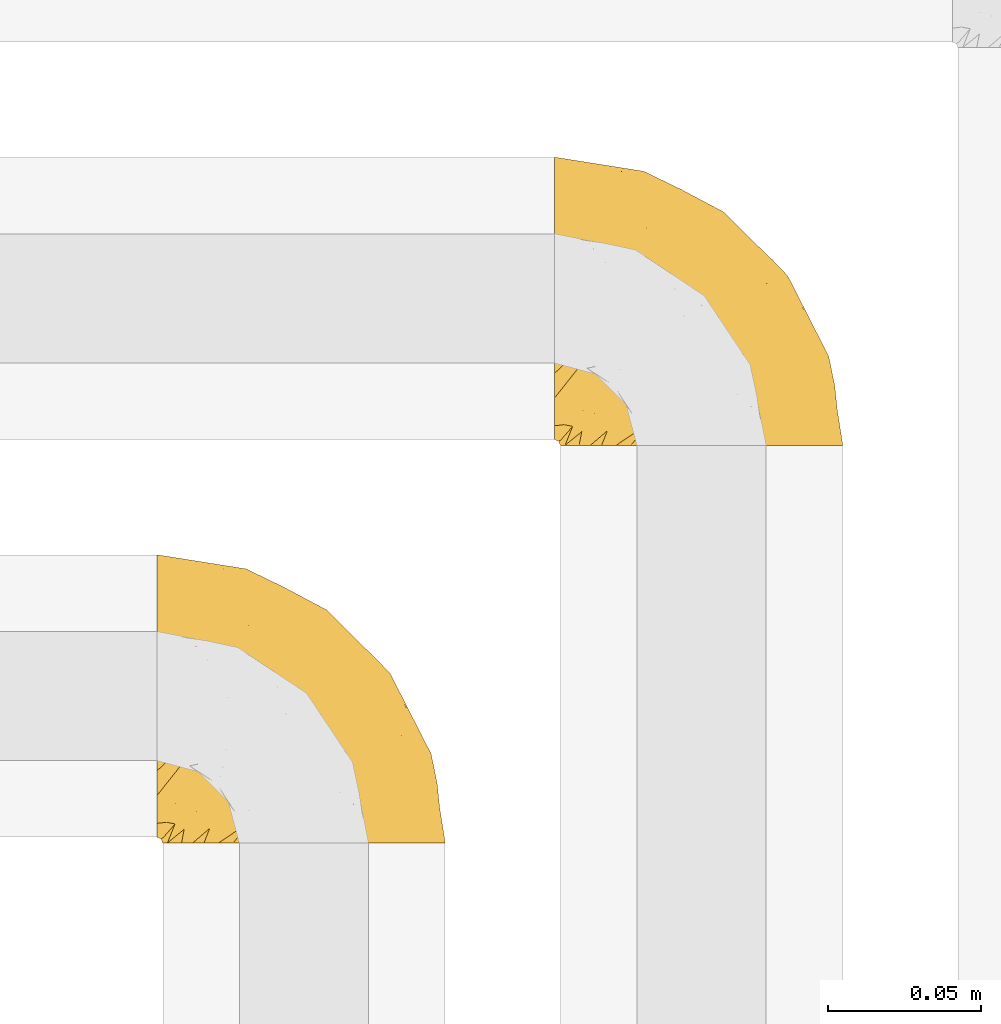
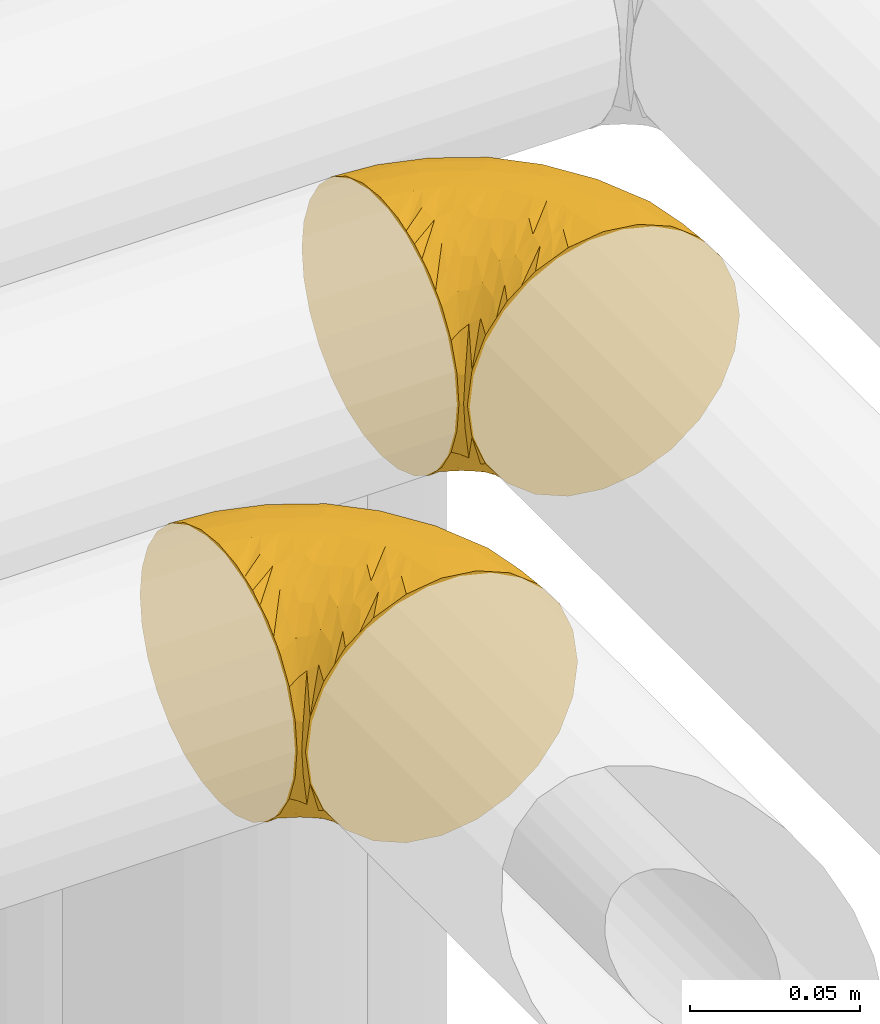
# One storey, part 261 of 827: 2 coverings.
"""IFC2X3 building model written with IfcOpenShell, lengths in millimetres."""

from ifc_helpers import new_model, entity, si_unit, converted_unit, derived_unit, direction, frame, origin, place, context, subcontext, project, spatial, faceted_brep, element, save


model = new_model("IFC2X3")

# Units and contexts
model_context = context("Model", 3, precision=0.01, world=origin(), true_north=direction((6.12303176911189e-17, 1.0)))
body_context = subcontext(model_context, "Body", "Model", "MODEL_VIEW")
ifc_project = project(units=[si_unit("LENGTHUNIT", "METRE", prefix="MILLI"), si_unit("AREAUNIT", "SQUARE_METRE"), si_unit("VOLUMEUNIT", "CUBIC_METRE"), converted_unit("PLANEANGLEUNIT", "DEGREE", entity("IfcRatioMeasure", 0.0174532925199433), si_unit("PLANEANGLEUNIT", "RADIAN"), dimensions=[0, 0, 0, 0, 0, 0, 0]), si_unit("MASSUNIT", "GRAM", prefix="KILO"), derived_unit("MASSDENSITYUNIT", [(si_unit("MASSUNIT", "GRAM", prefix="KILO"), 1), (si_unit("LENGTHUNIT", "METRE"), -3)]), derived_unit("MOMENTOFINERTIAUNIT", [(si_unit("LENGTHUNIT", "METRE"), 4)]), si_unit("TIMEUNIT", "SECOND"), si_unit("FREQUENCYUNIT", "HERTZ"), si_unit("THERMODYNAMICTEMPERATUREUNIT", "DEGREE_CELSIUS"), derived_unit("THERMALTRANSMITTANCEUNIT", [(si_unit("MASSUNIT", "GRAM", prefix="KILO"), 1), (si_unit("THERMODYNAMICTEMPERATUREUNIT", "KELVIN"), -1), (si_unit("TIMEUNIT", "SECOND"), -3)]), derived_unit("VOLUMETRICFLOWRATEUNIT", [(si_unit("LENGTHUNIT", "METRE"), 3), (si_unit("TIMEUNIT", "SECOND"), -1)]), derived_unit("MASSFLOWRATEUNIT", [(si_unit("MASSUNIT", "GRAM", prefix="KILO"), 1), (si_unit("TIMEUNIT", "SECOND"), -1)]), derived_unit("ROTATIONALFREQUENCYUNIT", [(si_unit("TIMEUNIT", "SECOND"), -1)]), si_unit("ELECTRICCURRENTUNIT", "AMPERE"), si_unit("ELECTRICVOLTAGEUNIT", "VOLT"), si_unit("POWERUNIT", "WATT"), si_unit("FORCEUNIT", "NEWTON", prefix="KILO"), si_unit("ILLUMINANCEUNIT", "LUX"), si_unit("LUMINOUSFLUXUNIT", "LUMEN"), si_unit("LUMINOUSINTENSITYUNIT", "CANDELA"), derived_unit("USERDEFINED", [(si_unit("MASSUNIT", "GRAM", prefix="KILO"), -1), (si_unit("LENGTHUNIT", "METRE"), -2), (si_unit("TIMEUNIT", "SECOND"), 3), (si_unit("LUMINOUSFLUXUNIT", "LUMEN"), 1)]), derived_unit("LINEARVELOCITYUNIT", [(si_unit("LENGTHUNIT", "METRE"), 1), (si_unit("TIMEUNIT", "SECOND"), -1)]), si_unit("PRESSUREUNIT", "PASCAL"), derived_unit("USERDEFINED", [(si_unit("LENGTHUNIT", "METRE"), -2), (si_unit("MASSUNIT", "GRAM", prefix="KILO"), 1), (si_unit("TIMEUNIT", "SECOND"), -2)]), derived_unit("LINEARFORCEUNIT", [(si_unit("MASSUNIT", "GRAM", prefix="KILO"), 1), (si_unit("LENGTHUNIT", "METRE"), 1), (si_unit("TIMEUNIT", "SECOND"), -2), (si_unit("LENGTHUNIT", "METRE"), -1)]), derived_unit("PLANARFORCEUNIT", [(si_unit("MASSUNIT", "GRAM", prefix="KILO"), 1), (si_unit("LENGTHUNIT", "METRE"), 1), (si_unit("TIMEUNIT", "SECOND"), -2), (si_unit("LENGTHUNIT", "METRE"), -2)])], contexts=[model_context])

# Site, building, storey
site_placement = place(None, origin())
site = spatial("IfcSite", under=ifc_project, at=site_placement, CompositionType="ELEMENT")
building_placement = place(site_placement, origin())
building = spatial("IfcBuilding", under=site, at=building_placement, CompositionType="ELEMENT")
storey_placement = place(building_placement, frame((0.0, 0.0, 28200.0)))
storey = spatial("IfcBuildingStorey", under=building, at=storey_placement, Name="08", CompositionType="ELEMENT", Elevation=28200.0)

# Coverings
covering_1_placement = place(storey_placement, frame((30996.93, 17071.61, 2952.2)))
element("IfcCovering", 1, at=covering_1_placement, inside=storey, Name=":ADSK_", ObjectType=":ADSK_", PredefinedType="INSULATION", context=body_context, shape_type="Brep", body=[
    faceted_brep([(1.6, 59.88, 92.84), (1.6, 69.65, 89.42), (1.6, 78.41, 83.91), (1.6, 85.72, 76.59), (1.6, 91.22, 67.83), (1.6, 94.64, 58.07), (1.6, 95.8, 47.8), (1.6, 94.64, 37.51), (1.6, 91.22, 27.74), (1.6, 85.71, 18.98), (1.6, 78.39, 11.67), (1.6, 69.63, 6.17), (1.6, 59.87, 2.75), (1.6, 49.6, 1.6), (1.6, 45.45, 2.06), (1.6, 42.38, 2.41), (1.6, 39.31, 2.75), (1.6, 34.43, 4.46), (1.6, 29.54, 6.17), (1.6, 25.16, 8.93), (1.6, 20.78, 11.68), (1.6, 17.13, 15.34), (1.6, 13.47, 19.0), (1.6, 7.97, 27.76), (1.6, 6.26, 32.64), (1.6, 4.55, 37.52), (1.6, 3.4, 47.8), (1.6, 4.55, 58.08), (1.6, 6.26, 62.96), (1.6, 7.97, 67.85), (1.6, 13.48, 76.61), (1.6, 17.14, 80.26), (1.6, 20.8, 83.92), (1.6, 25.18, 86.67), (1.6, 29.56, 89.42), (1.6, 34.44, 91.13), (1.6, 39.32, 92.84), (1.6, 42.39, 93.18), (1.6, 45.45, 93.53), (1.6, 49.6, 94.0), (3.4, 1.6, 47.8), (4.97, 1.6, 35.84), (9.58, 1.6, 24.7), (13.26, 1.6, 19.91), (16.93, 1.6, 15.13), (21.71, 1.6, 11.46), (26.5, 1.6, 7.78), (32.07, 1.6, 5.48), (37.64, 1.6, 3.17), (41.25, 1.6, 2.69), (43.34, 1.6, 2.42), (45.42, 1.6, 2.14), (49.6, 1.6, 1.6), (61.55, 1.6, 3.17), (72.7, 1.6, 7.78), (82.26, 1.6, 15.13), (89.61, 1.6, 24.7), (94.22, 1.6, 35.84), (95.8, 1.6, 47.8), (94.22, 1.6, 59.75), (89.61, 1.6, 70.9), (82.26, 1.6, 80.46), (72.7, 1.6, 87.81), (61.55, 1.6, 92.42), (49.6, 1.6, 94.0), (45.42, 1.6, 93.45), (41.25, 1.6, 92.9), (37.64, 1.6, 92.42), (32.07, 1.6, 90.11), (26.5, 1.6, 87.81), (21.71, 1.6, 84.13), (16.93, 1.6, 80.46), (13.26, 1.6, 75.68), (9.58, 1.6, 70.9), (4.97, 1.6, 59.75), (81.55, 36.81, 71.98), (90.4, 23.28, 63.6), (83.0, 45.8, 59.72), (91.18, 30.7, 47.8), (93.13, 21.2, 55.16), (94.0, 12.96, 47.8), (66.19, 66.19, 63.76), (70.92, 54.51, 72.22), (85.95, 17.98, 74.18), (49.74, 36.69, 92.52), (35.54, 35.54, 94.0), (38.14, 31.64, 94.0), (40.74, 27.75, 94.0), (43.34, 23.86, 94.0), (45.94, 19.96, 94.0), (77.59, 22.8, 82.14), (71.17, 42.67, 80.34), (65.81, 33.21, 87.52), (59.03, 59.45, 79.59), (45.85, 71.5, 78.25), (45.79, 62.66, 85.01), (41.42, 54.5, 90.25), (34.51, 47.57, 93.2), (56.04, 48.81, 87.23), (15.15, 74.98, 85.55), (56.51, 18.7, 93.0), (68.39, 15.75, 89.31), (23.33, 91.17, 61.31), (42.86, 85.28, 56.86), (39.42, 82.58, 68.34), (53.58, 75.78, 65.71), (59.17, 74.98, 56.99), (59.06, 67.27, 72.15), (22.63, 87.38, 70.34), (20.55, 82.04, 78.36), (12.96, 94.0, 47.8), (56.96, 77.8, 47.8), (67.38, 67.38, 47.8), (18.72, 56.2, 93.06), (5.33, 48.85, 94.0), (9.07, 48.11, 94.0), (11.79, 47.57, 94.0), (14.51, 47.03, 94.0), (17.24, 46.48, 94.0), (19.96, 45.94, 94.0), (21.03, 65.78, 89.88), (46.48, 17.24, 94.0), (47.03, 14.51, 94.0), (47.57, 11.79, 94.0), (48.11, 9.07, 94.0), (48.48, 7.2, 94.0), (48.85, 5.33, 94.0), (30.7, 91.18, 47.8), (23.86, 43.34, 94.0), (27.75, 40.74, 94.0), (31.64, 38.14, 94.0), (31.26, 72.73, 83.7), (77.8, 56.96, 47.8), (72.75, 62.23, 55.9), (43.83, 84.49, 47.8), (84.49, 43.83, 47.8), (14.58, 12.05, 81.75), (16.17, 18.95, 86.43), (10.82, 13.02, 79.8), (4.64, 8.34, 69.84), (7.71, 14.63, 79.5), (25.13, 11.09, 88.08), (32.66, 13.66, 91.6), (34.94, 20.08, 92.93), (36.76, 9.61, 92.43), (40.48, 9.48, 93.24), (39.25, 16.1, 93.36), (3.69, 3.42, 57.25), (13.99, 26.63, 89.41), (21.85, 33.72, 92.89), (17.93, 34.77, 92.66), (15.11, 6.75, 79.58), (21.14, 13.31, 86.51), (7.21, 19.94, 83.91), (9.47, 27.05, 88.76), (10.45, 6.04, 73.94), (32.27, 8.67, 90.94), (25.68, 26.11, 91.94), (22.18, 29.3, 91.98), (18.79, 6.32, 82.79), (10.12, 39.92, 93.16), (11.29, 34.4, 91.89), (2.87, 2.87, 47.8), (31.16, 20.92, 92.22), (12.7, 21.11, 86.29), (6.31, 27.43, 88.56), (25.62, 7.54, 87.72), (21.18, 18.45, 88.33), (28.81, 23.88, 92.18), (7.45, 7.77, 71.78), (21.17, 18.43, 7.27), (16.17, 18.93, 9.17), (25.69, 26.08, 3.66), (48.85, 5.33, 1.6), (47.03, 14.51, 1.6), (47.57, 11.79, 1.6), (48.11, 9.07, 1.6), (3.69, 3.42, 38.35), (7.44, 7.76, 23.84), (14.51, 47.03, 1.6), (11.79, 47.57, 1.6), (5.33, 48.85, 1.6), (9.07, 48.11, 1.6), (7.71, 14.62, 16.1), (9.47, 27.03, 6.84), (34.94, 20.08, 2.66), (31.16, 20.92, 3.37), (40.74, 27.75, 1.6), (38.14, 31.64, 1.6), (18.79, 6.33, 12.8), (36.76, 9.61, 3.16), (40.48, 9.48, 2.35), (4.63, 8.33, 25.77), (21.14, 13.3, 9.09), (15.11, 6.74, 16.02), (14.58, 12.04, 13.85), (43.34, 23.86, 1.6), (45.94, 19.96, 1.6), (39.25, 16.1, 2.23), (7.21, 19.93, 11.69), (12.69, 21.1, 9.31), (10.14, 39.92, 2.43), (21.81, 33.68, 2.71), (22.19, 29.28, 3.61), (14.0, 26.62, 6.18), (6.66, 27.87, 6.77), (17.92, 34.75, 2.93), (10.45, 6.04, 21.66), (31.64, 38.14, 1.6), (10.64, 12.79, 16.09), (11.31, 34.41, 3.7), (19.96, 45.94, 1.6), (23.86, 43.34, 1.6), (27.75, 40.74, 1.6), (32.66, 13.66, 3.99), (46.48, 17.24, 1.6), (32.27, 8.67, 4.65), (25.13, 11.09, 7.51), (35.54, 35.54, 1.6), (28.77, 23.83, 3.43), (23.36, 6.03, 9.46), (17.24, 46.48, 1.6), (47.58, 34.52, 2.4), (93.13, 21.2, 40.43), (77.44, 23.82, 13.57), (66.78, 41.32, 11.3), (71.68, 47.62, 18.65), (74.96, 52.66, 27.26), (81.55, 36.81, 23.61), (36.7, 49.75, 3.07), (56.9, 19.07, 2.69), (83.0, 45.8, 35.87), (90.4, 23.28, 31.99), (67.83, 21.35, 6.71), (85.95, 17.98, 21.41), (39.41, 82.57, 27.24), (23.33, 91.17, 34.26), (42.87, 85.27, 38.73), (53.92, 73.89, 26.97), (66.19, 66.19, 31.83), (64.12, 62.43, 23.4), (33.13, 63.53, 6.91), (23.1, 58.45, 3.4), (16.98, 67.16, 5.84), (72.75, 62.22, 39.69), (23.77, 81.54, 17.6), (18.41, 74.8, 10.38), (43.7, 75.83, 20.6), (54.53, 41.45, 5.36), (55.72, 76.72, 35.73), (17.73, 88.2, 24.84), (38.98, 71.6, 13.87), (50.28, 56.23, 9.06), (59.02, 59.44, 15.99)], [[[0, 1, 2, 3, 4, 5, 6, 7, 8, 9, 10, 11, 12, 13, 14, 15, 16, 17, 18, 19, 20, 21, 22, 23, 24, 25, 26, 27, 28, 29, 30, 31, 32, 33, 34, 35, 36, 37, 38, 39]], [[40, 41, 42, 43, 44, 45, 46, 47, 48, 49, 50, 51, 52, 53, 54, 55, 56, 57, 58, 59, 60, 61, 62, 63, 64, 65, 66, 67, 68, 69, 70, 71, 72, 73, 74]], [[75, 76, 77]], [[78, 79, 80]], [[77, 81, 82]], [[76, 75, 83]], [[84, 85, 86, 87, 88, 89]], [[90, 91, 92]], [[76, 60, 59]], [[93, 94, 95]], [[90, 62, 61]], [[83, 61, 60]], [[96, 97, 84]], [[98, 93, 95]], [[2, 1, 99]], [[100, 84, 89]], [[62, 101, 63]], [[4, 102, 5]], [[92, 84, 100]], [[103, 102, 104]], [[103, 105, 106]], [[93, 107, 94]], [[3, 108, 4]], [[92, 101, 90]], [[108, 3, 109]], [[102, 110, 5]], [[93, 82, 107]], [[102, 108, 104]], [[111, 106, 112]], [[109, 2, 99]], [[113, 39, 114, 115, 116, 117, 118, 119]], [[120, 0, 113]], [[100, 89, 121, 122, 123, 124, 125, 126, 64]], [[127, 102, 103]], [[97, 119, 128, 129, 130, 85]], [[99, 120, 131]], [[132, 133, 77]], [[59, 80, 79]], [[3, 2, 109]], [[98, 84, 92]], [[94, 109, 131]], [[120, 1, 0]], [[93, 91, 82]], [[104, 94, 105]], [[97, 113, 119]], [[95, 120, 96]], [[83, 90, 61]], [[91, 93, 98]], [[64, 63, 100]], [[100, 63, 101]], [[77, 76, 79]], [[133, 106, 81]], [[84, 97, 85]], [[113, 96, 120]], [[113, 97, 96]], [[39, 113, 0]], [[110, 102, 127]], [[110, 6, 5]], [[103, 111, 134, 127]], [[90, 75, 91]], [[82, 81, 107]], [[91, 75, 82]], [[77, 82, 75]], [[76, 83, 60]], [[90, 83, 75]], [[105, 107, 81]], [[94, 131, 95]], [[105, 94, 107]], [[109, 94, 104]], [[120, 95, 131]], [[98, 95, 96]], [[84, 98, 96]], [[98, 92, 91]], [[106, 105, 81]], [[103, 104, 105]], [[112, 106, 133]], [[103, 106, 111]], [[112, 133, 132]], [[81, 77, 133]], [[77, 78, 135, 132]], [[120, 99, 1]], [[109, 99, 131]], [[59, 58, 80]], [[59, 79, 76]], [[90, 101, 62]], [[100, 101, 92]], [[4, 108, 102]], [[109, 104, 108]], [[78, 77, 79]], [[136, 137, 138]], [[29, 139, 140]], [[141, 142, 143]], [[144, 145, 121]], [[146, 89, 88]], [[147, 139, 27]], [[148, 149, 150]], [[136, 151, 152]], [[147, 40, 74]], [[26, 147, 27]], [[153, 148, 154]], [[35, 116, 36]], [[73, 151, 155]], [[114, 39, 38, 37, 36, 116, 115]], [[146, 156, 144]], [[157, 85, 130]], [[158, 149, 148]], [[151, 159, 152]], [[117, 35, 160]], [[31, 153, 154]], [[155, 74, 73]], [[161, 128, 119]], [[66, 65, 64, 126, 125, 124, 123, 122, 67]], [[162, 147, 26]], [[29, 140, 30]], [[149, 129, 150]], [[139, 29, 28, 27]], [[68, 144, 69]], [[129, 128, 150]], [[163, 87, 86]], [[130, 129, 149]], [[122, 145, 67]], [[153, 164, 148]], [[161, 119, 160]], [[165, 32, 154]], [[150, 154, 148]], [[128, 161, 150]], [[32, 165, 33]], [[145, 144, 68]], [[89, 146, 144]], [[87, 163, 143]], [[166, 156, 142]], [[88, 87, 143]], [[161, 154, 150]], [[154, 32, 31]], [[31, 30, 153]], [[30, 140, 153]], [[164, 153, 140]], [[140, 137, 164]], [[158, 148, 164]], [[157, 130, 158]], [[164, 137, 158]], [[158, 137, 157]], [[167, 137, 136]], [[168, 85, 157]], [[152, 168, 167]], [[167, 168, 157]], [[163, 152, 141]], [[151, 73, 72]], [[159, 72, 71]], [[88, 142, 146]], [[144, 156, 69]], [[146, 142, 156]], [[70, 166, 71]], [[142, 141, 166]], [[70, 69, 156]], [[141, 159, 71]], [[167, 136, 152]], [[138, 137, 140]], [[155, 136, 169]], [[136, 155, 151]], [[74, 155, 169]], [[152, 159, 141]], [[151, 72, 159]], [[168, 152, 163]], [[137, 167, 157]], [[163, 86, 168]], [[85, 168, 86]], [[116, 35, 117]], [[130, 149, 158]], [[67, 145, 68]], [[121, 89, 144]], [[145, 122, 121]], [[40, 147, 162]], [[169, 147, 74]], [[160, 35, 34]], [[161, 160, 34]], [[160, 119, 118, 117]], [[139, 147, 169]], [[139, 169, 138]], [[161, 34, 33]], [[141, 143, 163]], [[88, 143, 142]], [[71, 166, 141]], [[156, 166, 70]], [[139, 138, 140]], [[169, 136, 138]], [[154, 161, 165]], [[161, 33, 165]], [[170, 171, 172]], [[173, 52, 51, 50, 49, 48, 174, 175, 176]], [[177, 178, 41]], [[179, 17, 180]], [[14, 13, 181, 182, 180, 16, 15]], [[183, 23, 22]], [[21, 20, 184]], [[185, 186, 187]], [[186, 188, 187]], [[43, 189, 44]], [[190, 191, 47]], [[25, 24, 23, 192]], [[193, 194, 195]], [[40, 162, 177]], [[196, 197, 198]], [[26, 25, 177]], [[199, 200, 183]], [[201, 17, 179]], [[178, 177, 192]], [[47, 46, 190]], [[202, 203, 204]], [[203, 172, 171]], [[205, 206, 184]], [[207, 41, 178]], [[18, 17, 201]], [[16, 180, 17]], [[204, 203, 200]], [[208, 203, 202]], [[162, 26, 177]], [[48, 47, 191]], [[198, 197, 190]], [[199, 184, 204]], [[171, 195, 209]], [[210, 211, 212]], [[206, 212, 213]], [[205, 19, 210]], [[184, 206, 204]], [[210, 212, 206]], [[185, 196, 214]], [[190, 215, 191]], [[216, 45, 214]], [[186, 217, 193]], [[190, 216, 198]], [[199, 22, 21]], [[196, 185, 187]], [[199, 183, 22]], [[184, 199, 21]], [[199, 204, 200]], [[206, 202, 204]], [[171, 183, 200]], [[203, 208, 172]], [[172, 208, 218]], [[171, 200, 203]], [[218, 188, 219]], [[195, 170, 193]], [[217, 186, 185]], [[193, 219, 186]], [[193, 170, 219]], [[207, 194, 42]], [[217, 220, 189]], [[216, 190, 46]], [[214, 196, 198]], [[44, 220, 45]], [[214, 198, 216]], [[216, 46, 45]], [[214, 45, 220]], [[42, 194, 43]], [[189, 193, 217]], [[207, 195, 194]], [[209, 195, 178]], [[41, 207, 42]], [[195, 207, 178]], [[43, 194, 189]], [[193, 189, 194]], [[171, 170, 195]], [[170, 172, 219]], [[218, 219, 172]], [[188, 186, 219]], [[206, 213, 202]], [[208, 202, 213]], [[201, 210, 18]], [[215, 190, 197]], [[215, 174, 191]], [[174, 48, 191]], [[201, 179, 221, 211]], [[210, 201, 211]], [[25, 192, 177]], [[40, 177, 41]], [[192, 183, 209]], [[23, 183, 192]], [[205, 20, 19]], [[19, 18, 210]], [[217, 185, 214]], [[189, 220, 44]], [[214, 220, 217]], [[192, 209, 178]], [[171, 209, 183]], [[206, 205, 210]], [[20, 205, 184]], [[222, 197, 196, 187, 188, 218]], [[57, 223, 80]], [[224, 225, 226]], [[226, 227, 228]], [[229, 218, 208, 213, 212, 211]], [[230, 52, 173, 176, 175, 174, 215, 197]], [[231, 232, 228]], [[231, 78, 223]], [[223, 57, 232]], [[224, 233, 225]], [[233, 54, 53]], [[234, 232, 56]], [[56, 55, 234]], [[234, 224, 228]], [[235, 236, 237]], [[224, 55, 54]], [[238, 239, 240]], [[52, 230, 53]], [[241, 242, 243]], [[231, 227, 244]], [[13, 12, 242]], [[236, 8, 7]], [[9, 245, 10]], [[10, 246, 11]], [[238, 247, 235]], [[222, 229, 248]], [[242, 211, 221, 179, 180, 182, 181, 13]], [[233, 53, 230]], [[111, 112, 249]], [[250, 8, 236]], [[246, 251, 241]], [[8, 250, 9]], [[127, 236, 110]], [[248, 229, 252]], [[246, 10, 245]], [[235, 245, 250]], [[236, 7, 110]], [[235, 249, 238]], [[237, 236, 127]], [[243, 11, 246]], [[252, 229, 241]], [[56, 232, 57]], [[222, 230, 197]], [[225, 248, 252]], [[248, 233, 230]], [[54, 233, 224]], [[231, 228, 227]], [[244, 132, 231]], [[248, 225, 233]], [[226, 225, 253]], [[235, 250, 236]], [[245, 9, 250]], [[251, 246, 245]], [[243, 246, 241]], [[247, 245, 235]], [[252, 251, 253]], [[229, 222, 218]], [[230, 222, 248]], [[7, 6, 110]], [[237, 127, 134, 111]], [[238, 249, 239]], [[224, 234, 55]], [[232, 234, 228]], [[242, 241, 229]], [[12, 11, 243]], [[211, 242, 229]], [[12, 243, 242]], [[80, 223, 78]], [[80, 58, 57]], [[231, 223, 232]], [[227, 240, 239]], [[224, 226, 228]], [[240, 226, 253]], [[227, 239, 244]], [[226, 240, 227]], [[251, 247, 253]], [[240, 253, 247]], [[249, 235, 237]], [[237, 111, 249]], [[244, 239, 249]], [[112, 244, 249]], [[135, 78, 231, 132]], [[112, 132, 244]], [[247, 238, 240]], [[245, 247, 251]], [[251, 252, 241]], [[225, 252, 253]]]),
])
covering_2_placement = place(storey_placement, frame((30866.93, 16941.61, 2952.2)))
element("IfcCovering", 2, at=covering_2_placement, inside=storey, Name=":ADSK_", ObjectType=":ADSK_", PredefinedType="INSULATION", context=body_context, shape_type="Brep", body=[
    faceted_brep([(1.6, 59.88, 92.84), (1.6, 69.65, 89.42), (1.6, 78.41, 83.91), (1.6, 85.72, 76.59), (1.6, 91.22, 67.83), (1.6, 94.64, 58.07), (1.6, 95.8, 47.8), (1.6, 94.64, 37.51), (1.6, 91.22, 27.74), (1.6, 85.71, 18.98), (1.6, 78.39, 11.67), (1.6, 69.63, 6.17), (1.6, 59.87, 2.75), (1.6, 49.6, 1.6), (1.6, 45.45, 2.06), (1.6, 42.38, 2.41), (1.6, 39.31, 2.75), (1.6, 34.43, 4.46), (1.6, 29.54, 6.17), (1.6, 25.16, 8.93), (1.6, 20.78, 11.68), (1.6, 17.13, 15.34), (1.6, 13.47, 19.0), (1.6, 7.97, 27.76), (1.6, 6.26, 32.64), (1.6, 4.55, 37.52), (1.6, 3.4, 47.8), (1.6, 4.55, 58.08), (1.6, 6.26, 62.96), (1.6, 7.97, 67.85), (1.6, 13.48, 76.61), (1.6, 17.14, 80.26), (1.6, 20.8, 83.92), (1.6, 25.18, 86.67), (1.6, 29.56, 89.42), (1.6, 34.44, 91.13), (1.6, 39.32, 92.84), (1.6, 42.39, 93.18), (1.6, 45.45, 93.53), (1.6, 49.6, 94.0), (3.4, 1.6, 47.8), (4.97, 1.6, 35.84), (9.58, 1.6, 24.7), (13.26, 1.6, 19.91), (16.93, 1.6, 15.13), (21.71, 1.6, 11.46), (26.5, 1.6, 7.78), (32.07, 1.6, 5.48), (37.64, 1.6, 3.17), (41.25, 1.6, 2.69), (43.34, 1.6, 2.42), (45.42, 1.6, 2.14), (49.6, 1.6, 1.6), (61.55, 1.6, 3.17), (72.7, 1.6, 7.78), (82.26, 1.6, 15.13), (89.61, 1.6, 24.7), (94.22, 1.6, 35.84), (95.8, 1.6, 47.8), (94.22, 1.6, 59.75), (89.61, 1.6, 70.9), (82.26, 1.6, 80.46), (72.7, 1.6, 87.81), (61.55, 1.6, 92.42), (49.6, 1.6, 94.0), (45.42, 1.6, 93.45), (41.25, 1.6, 92.9), (37.64, 1.6, 92.42), (32.07, 1.6, 90.11), (26.5, 1.6, 87.81), (21.71, 1.6, 84.13), (16.93, 1.6, 80.46), (13.26, 1.6, 75.68), (9.58, 1.6, 70.9), (4.97, 1.6, 59.75), (81.55, 36.81, 71.98), (90.4, 23.28, 63.6), (83.0, 45.8, 59.72), (91.18, 30.7, 47.8), (93.13, 21.2, 55.16), (94.0, 12.96, 47.8), (66.19, 66.19, 63.76), (70.92, 54.51, 72.22), (85.95, 17.98, 74.18), (49.74, 36.69, 92.52), (35.54, 35.54, 94.0), (38.14, 31.64, 94.0), (40.74, 27.75, 94.0), (43.34, 23.86, 94.0), (45.94, 19.96, 94.0), (77.59, 22.8, 82.14), (71.17, 42.67, 80.34), (65.81, 33.21, 87.52), (59.03, 59.45, 79.59), (45.85, 71.5, 78.25), (45.79, 62.66, 85.01), (41.42, 54.5, 90.25), (34.51, 47.57, 93.2), (56.04, 48.81, 87.23), (15.15, 74.98, 85.55), (56.51, 18.7, 93.0), (68.39, 15.75, 89.31), (23.33, 91.17, 61.31), (42.86, 85.28, 56.86), (39.42, 82.58, 68.34), (53.58, 75.78, 65.71), (59.17, 74.98, 56.99), (59.06, 67.27, 72.15), (22.63, 87.38, 70.34), (20.55, 82.04, 78.36), (12.96, 94.0, 47.8), (56.96, 77.8, 47.8), (67.38, 67.38, 47.8), (18.72, 56.2, 93.06), (5.33, 48.85, 94.0), (9.07, 48.11, 94.0), (11.79, 47.57, 94.0), (14.51, 47.03, 94.0), (17.24, 46.48, 94.0), (19.96, 45.94, 94.0), (21.03, 65.78, 89.88), (46.48, 17.24, 94.0), (47.03, 14.51, 94.0), (47.57, 11.79, 94.0), (48.11, 9.07, 94.0), (48.48, 7.2, 94.0), (48.85, 5.33, 94.0), (30.7, 91.18, 47.8), (23.86, 43.34, 94.0), (27.75, 40.74, 94.0), (31.64, 38.14, 94.0), (31.26, 72.73, 83.7), (77.8, 56.96, 47.8), (72.75, 62.23, 55.9), (43.83, 84.49, 47.8), (84.49, 43.83, 47.8), (14.58, 12.05, 81.75), (16.17, 18.95, 86.43), (10.82, 13.02, 79.8), (4.64, 8.34, 69.84), (7.71, 14.63, 79.5), (25.13, 11.09, 88.08), (32.66, 13.66, 91.6), (34.94, 20.08, 92.93), (36.76, 9.61, 92.43), (40.48, 9.48, 93.24), (39.25, 16.1, 93.36), (3.69, 3.42, 57.25), (13.99, 26.63, 89.41), (21.85, 33.72, 92.89), (17.93, 34.77, 92.66), (15.11, 6.75, 79.58), (21.14, 13.31, 86.51), (7.21, 19.94, 83.91), (9.47, 27.05, 88.76), (32.27, 8.67, 90.94), (25.68, 26.11, 91.94), (22.18, 29.3, 91.98), (18.79, 6.32, 82.79), (10.12, 39.92, 93.16), (10.45, 6.04, 73.94), (11.29, 34.4, 91.89), (2.87, 2.87, 47.8), (31.16, 20.92, 92.22), (12.7, 21.11, 86.29), (6.31, 27.43, 88.56), (25.62, 7.54, 87.72), (21.18, 18.45, 88.33), (28.81, 23.88, 92.18), (7.45, 7.77, 71.78), (21.14, 13.3, 9.09), (25.13, 11.09, 7.51), (18.79, 6.33, 12.8), (48.85, 5.33, 1.6), (47.03, 14.51, 1.6), (47.57, 11.79, 1.6), (48.11, 9.07, 1.6), (3.69, 3.42, 38.35), (7.44, 7.76, 23.84), (14.51, 47.03, 1.6), (11.79, 47.57, 1.6), (5.33, 48.85, 1.6), (9.07, 48.11, 1.6), (7.71, 14.62, 16.1), (9.47, 27.03, 6.84), (34.94, 20.08, 2.66), (31.16, 20.92, 3.37), (40.74, 27.75, 1.6), (38.14, 31.64, 1.6), (36.76, 9.61, 3.16), (40.48, 9.48, 2.35), (4.63, 8.33, 25.77), (15.11, 6.74, 16.02), (14.58, 12.04, 13.85), (43.34, 23.86, 1.6), (45.94, 19.96, 1.6), (39.25, 16.1, 2.23), (7.21, 19.93, 11.69), (12.69, 21.1, 9.31), (10.14, 39.92, 2.43), (21.81, 33.68, 2.71), (22.19, 29.28, 3.61), (14.0, 26.62, 6.18), (25.69, 26.08, 3.66), (16.17, 18.93, 9.17), (6.66, 27.87, 6.77), (17.92, 34.75, 2.93), (10.45, 6.04, 21.66), (31.64, 38.14, 1.6), (10.64, 12.79, 16.09), (11.31, 34.41, 3.7), (19.96, 45.94, 1.6), (23.86, 43.34, 1.6), (27.75, 40.74, 1.6), (32.66, 13.66, 3.99), (46.48, 17.24, 1.6), (32.27, 8.67, 4.65), (35.54, 35.54, 1.6), (28.77, 23.83, 3.43), (21.17, 18.43, 7.27), (23.36, 6.03, 9.46), (17.24, 46.48, 1.6), (47.58, 34.52, 2.4), (93.13, 21.2, 40.43), (77.44, 23.82, 13.57), (66.78, 41.32, 11.3), (71.68, 47.62, 18.65), (74.96, 52.66, 27.26), (81.55, 36.81, 23.61), (36.7, 49.75, 3.07), (56.9, 19.07, 2.69), (83.0, 45.8, 35.87), (90.4, 23.28, 31.99), (67.83, 21.35, 6.71), (85.95, 17.98, 21.41), (39.41, 82.57, 27.24), (23.33, 91.17, 34.26), (42.87, 85.27, 38.73), (53.92, 73.89, 26.97), (66.19, 66.19, 31.83), (64.12, 62.43, 23.4), (33.13, 63.53, 6.91), (23.1, 58.45, 3.4), (16.98, 67.16, 5.84), (72.75, 62.22, 39.69), (23.77, 81.54, 17.6), (18.41, 74.8, 10.38), (43.7, 75.83, 20.6), (54.53, 41.45, 5.36), (55.72, 76.72, 35.73), (17.73, 88.2, 24.84), (38.98, 71.6, 13.87), (50.28, 56.23, 9.06), (59.02, 59.44, 15.99)], [[[0, 1, 2, 3, 4, 5, 6, 7, 8, 9, 10, 11, 12, 13, 14, 15, 16, 17, 18, 19, 20, 21, 22, 23, 24, 25, 26, 27, 28, 29, 30, 31, 32, 33, 34, 35, 36, 37, 38, 39]], [[40, 41, 42, 43, 44, 45, 46, 47, 48, 49, 50, 51, 52, 53, 54, 55, 56, 57, 58, 59, 60, 61, 62, 63, 64, 65, 66, 67, 68, 69, 70, 71, 72, 73, 74]], [[75, 76, 77]], [[78, 79, 80]], [[77, 81, 82]], [[76, 75, 83]], [[84, 85, 86, 87, 88, 89]], [[90, 91, 92]], [[76, 60, 59]], [[93, 94, 95]], [[90, 62, 61]], [[83, 61, 60]], [[96, 97, 84]], [[98, 93, 95]], [[2, 1, 99]], [[100, 84, 89]], [[62, 101, 63]], [[4, 102, 5]], [[92, 84, 100]], [[103, 102, 104]], [[103, 105, 106]], [[93, 107, 94]], [[3, 108, 4]], [[92, 101, 90]], [[108, 3, 109]], [[102, 110, 5]], [[93, 82, 107]], [[102, 108, 104]], [[111, 106, 112]], [[109, 2, 99]], [[113, 39, 114, 115, 116, 117, 118, 119]], [[120, 0, 113]], [[100, 89, 121, 122, 123, 124, 125, 126, 64]], [[127, 102, 103]], [[97, 119, 128, 129, 130, 85]], [[99, 120, 131]], [[132, 133, 77]], [[59, 80, 79]], [[3, 2, 109]], [[98, 84, 92]], [[94, 109, 131]], [[120, 1, 0]], [[93, 91, 82]], [[104, 94, 105]], [[97, 113, 119]], [[95, 120, 96]], [[83, 90, 61]], [[91, 93, 98]], [[64, 63, 100]], [[100, 63, 101]], [[77, 76, 79]], [[133, 106, 81]], [[84, 97, 85]], [[113, 96, 120]], [[113, 97, 96]], [[39, 113, 0]], [[110, 102, 127]], [[110, 6, 5]], [[103, 111, 134, 127]], [[90, 75, 91]], [[82, 81, 107]], [[91, 75, 82]], [[77, 82, 75]], [[76, 83, 60]], [[90, 83, 75]], [[105, 107, 81]], [[94, 131, 95]], [[105, 94, 107]], [[109, 94, 104]], [[120, 95, 131]], [[98, 95, 96]], [[84, 98, 96]], [[98, 92, 91]], [[106, 105, 81]], [[103, 104, 105]], [[133, 132, 112]], [[103, 106, 111]], [[77, 78, 135, 132]], [[106, 133, 112]], [[77, 133, 81]], [[120, 99, 1]], [[109, 99, 131]], [[59, 58, 80]], [[59, 79, 76]], [[90, 101, 62]], [[100, 101, 92]], [[4, 108, 102]], [[109, 104, 108]], [[78, 77, 79]], [[136, 137, 138]], [[29, 139, 140]], [[141, 142, 143]], [[144, 145, 121]], [[146, 89, 88]], [[147, 139, 27]], [[148, 149, 150]], [[136, 151, 152]], [[147, 40, 74]], [[26, 147, 27]], [[153, 148, 154]], [[35, 116, 36]], [[73, 72, 151]], [[114, 39, 38, 37, 36, 116, 115]], [[146, 155, 144]], [[156, 85, 130]], [[157, 149, 148]], [[151, 158, 152]], [[117, 35, 159]], [[31, 153, 154]], [[160, 74, 73]], [[161, 128, 119]], [[66, 65, 64, 126, 125, 124, 123, 122, 67]], [[162, 147, 26]], [[29, 140, 30]], [[149, 129, 150]], [[139, 29, 28, 27]], [[68, 144, 69]], [[129, 128, 150]], [[163, 87, 86]], [[130, 129, 149]], [[122, 145, 67]], [[153, 164, 148]], [[161, 119, 159]], [[165, 32, 154]], [[150, 154, 148]], [[128, 161, 150]], [[32, 165, 33]], [[145, 144, 68]], [[89, 146, 144]], [[87, 163, 143]], [[166, 155, 142]], [[88, 87, 143]], [[161, 154, 150]], [[154, 32, 31]], [[31, 30, 153]], [[30, 140, 153]], [[164, 153, 140]], [[140, 137, 164]], [[157, 148, 164]], [[156, 130, 157]], [[164, 137, 157]], [[157, 137, 156]], [[167, 137, 136]], [[168, 85, 156]], [[152, 168, 167]], [[167, 168, 156]], [[163, 152, 141]], [[71, 158, 72]], [[152, 167, 136]], [[88, 142, 146]], [[144, 155, 69]], [[146, 142, 155]], [[70, 166, 71]], [[142, 141, 166]], [[70, 69, 155]], [[141, 158, 71]], [[160, 73, 151]], [[138, 137, 140]], [[160, 136, 169]], [[136, 160, 151]], [[74, 160, 169]], [[152, 158, 141]], [[151, 72, 158]], [[168, 152, 163]], [[137, 167, 156]], [[163, 86, 168]], [[85, 168, 86]], [[116, 35, 117]], [[130, 149, 157]], [[67, 145, 68]], [[121, 89, 144]], [[145, 122, 121]], [[40, 147, 162]], [[169, 147, 74]], [[159, 35, 34]], [[161, 159, 34]], [[159, 119, 118, 117]], [[139, 147, 169]], [[139, 169, 138]], [[161, 34, 33]], [[141, 143, 163]], [[88, 143, 142]], [[71, 166, 141]], [[155, 166, 70]], [[139, 138, 140]], [[169, 136, 138]], [[154, 161, 165]], [[161, 33, 165]], [[170, 171, 172]], [[173, 52, 51, 50, 49, 48, 174, 175, 176]], [[177, 178, 41]], [[179, 17, 180]], [[14, 13, 181, 182, 180, 16, 15]], [[183, 23, 22]], [[21, 20, 184]], [[185, 186, 187]], [[186, 188, 187]], [[43, 172, 44]], [[189, 190, 47]], [[25, 24, 23, 191]], [[170, 192, 193]], [[40, 162, 177]], [[194, 195, 196]], [[26, 25, 177]], [[197, 198, 183]], [[199, 17, 179]], [[47, 46, 189]], [[200, 201, 202]], [[201, 203, 204]], [[205, 206, 184]], [[207, 41, 178]], [[18, 17, 199]], [[16, 180, 17]], [[202, 201, 198]], [[208, 201, 200]], [[162, 26, 177]], [[48, 47, 190]], [[196, 195, 189]], [[197, 184, 202]], [[204, 193, 209]], [[210, 211, 212]], [[206, 212, 213]], [[205, 19, 210]], [[184, 206, 202]], [[210, 212, 206]], [[185, 194, 214]], [[189, 215, 190]], [[216, 45, 214]], [[186, 171, 170]], [[189, 216, 196]], [[197, 22, 21]], [[194, 185, 187]], [[197, 183, 22]], [[184, 197, 21]], [[197, 202, 198]], [[206, 200, 202]], [[204, 183, 198]], [[201, 208, 203]], [[203, 208, 217]], [[204, 198, 201]], [[217, 188, 218]], [[193, 219, 170]], [[171, 186, 185]], [[170, 218, 186]], [[170, 219, 218]], [[42, 207, 192]], [[171, 220, 172]], [[216, 189, 46]], [[214, 194, 196]], [[44, 220, 45]], [[214, 196, 216]], [[216, 46, 45]], [[214, 45, 220]], [[192, 43, 42]], [[204, 203, 219]], [[207, 193, 192]], [[209, 193, 178]], [[41, 207, 42]], [[193, 207, 178]], [[43, 192, 172]], [[170, 172, 192]], [[204, 219, 193]], [[219, 203, 218]], [[217, 218, 203]], [[188, 186, 218]], [[206, 213, 200]], [[208, 200, 213]], [[199, 210, 18]], [[215, 189, 195]], [[215, 174, 190]], [[174, 48, 190]], [[199, 179, 221, 211]], [[210, 199, 211]], [[25, 191, 177]], [[40, 177, 41]], [[183, 209, 191]], [[183, 191, 23]], [[191, 178, 177]], [[205, 20, 19]], [[19, 18, 210]], [[171, 185, 214]], [[172, 220, 44]], [[214, 220, 171]], [[191, 209, 178]], [[204, 209, 183]], [[206, 205, 210]], [[20, 205, 184]], [[222, 195, 194, 187, 188, 217]], [[57, 223, 80]], [[224, 225, 226]], [[226, 227, 228]], [[229, 217, 208, 213, 212, 211]], [[230, 52, 173, 176, 175, 174, 215, 195]], [[231, 232, 228]], [[231, 78, 223]], [[223, 57, 232]], [[224, 233, 225]], [[233, 54, 53]], [[234, 232, 56]], [[56, 55, 234]], [[234, 224, 228]], [[235, 236, 237]], [[224, 55, 54]], [[238, 239, 240]], [[52, 230, 53]], [[241, 242, 243]], [[231, 227, 244]], [[13, 12, 242]], [[236, 8, 7]], [[9, 245, 10]], [[10, 246, 11]], [[238, 247, 235]], [[222, 229, 248]], [[242, 211, 221, 179, 180, 182, 181, 13]], [[233, 53, 230]], [[111, 112, 249]], [[250, 8, 236]], [[246, 251, 241]], [[8, 250, 9]], [[127, 236, 110]], [[248, 229, 252]], [[246, 10, 245]], [[235, 245, 250]], [[236, 7, 110]], [[235, 249, 238]], [[237, 236, 127]], [[243, 11, 246]], [[252, 229, 241]], [[56, 232, 57]], [[222, 230, 195]], [[225, 248, 252]], [[248, 233, 230]], [[54, 233, 224]], [[231, 228, 227]], [[244, 132, 231]], [[248, 225, 233]], [[226, 225, 253]], [[235, 250, 236]], [[245, 9, 250]], [[251, 246, 245]], [[243, 246, 241]], [[247, 245, 235]], [[252, 251, 253]], [[229, 222, 217]], [[230, 222, 248]], [[7, 6, 110]], [[237, 127, 134, 111]], [[238, 249, 239]], [[224, 234, 55]], [[232, 234, 228]], [[242, 241, 229]], [[12, 11, 243]], [[211, 242, 229]], [[12, 243, 242]], [[80, 223, 78]], [[80, 58, 57]], [[231, 223, 232]], [[227, 240, 239]], [[224, 226, 228]], [[240, 226, 253]], [[227, 239, 244]], [[226, 240, 227]], [[251, 247, 253]], [[240, 253, 247]], [[249, 235, 237]], [[237, 111, 249]], [[244, 239, 249]], [[112, 244, 249]], [[135, 78, 231, 132]], [[112, 132, 244]], [[247, 238, 240]], [[245, 247, 251]], [[251, 252, 241]], [[225, 252, 253]]]),
])

save(model, "model.ifc")
